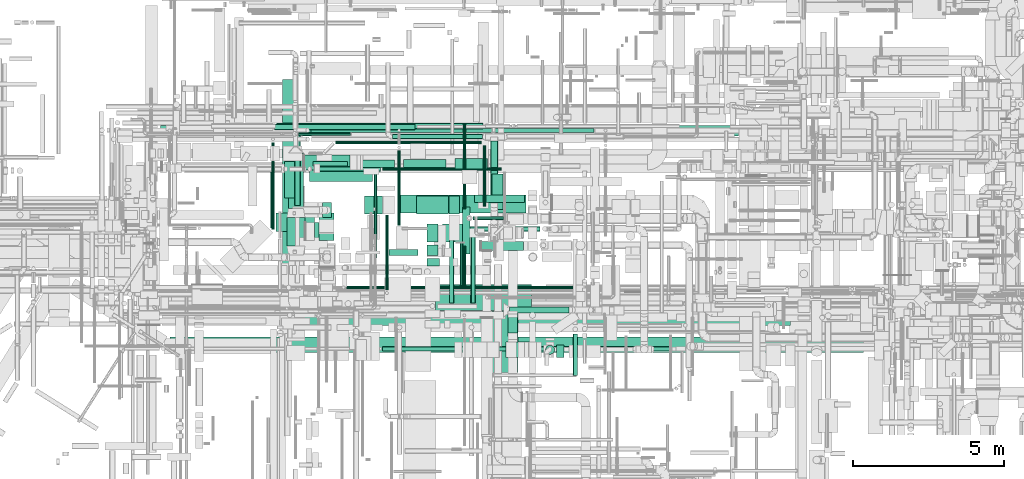
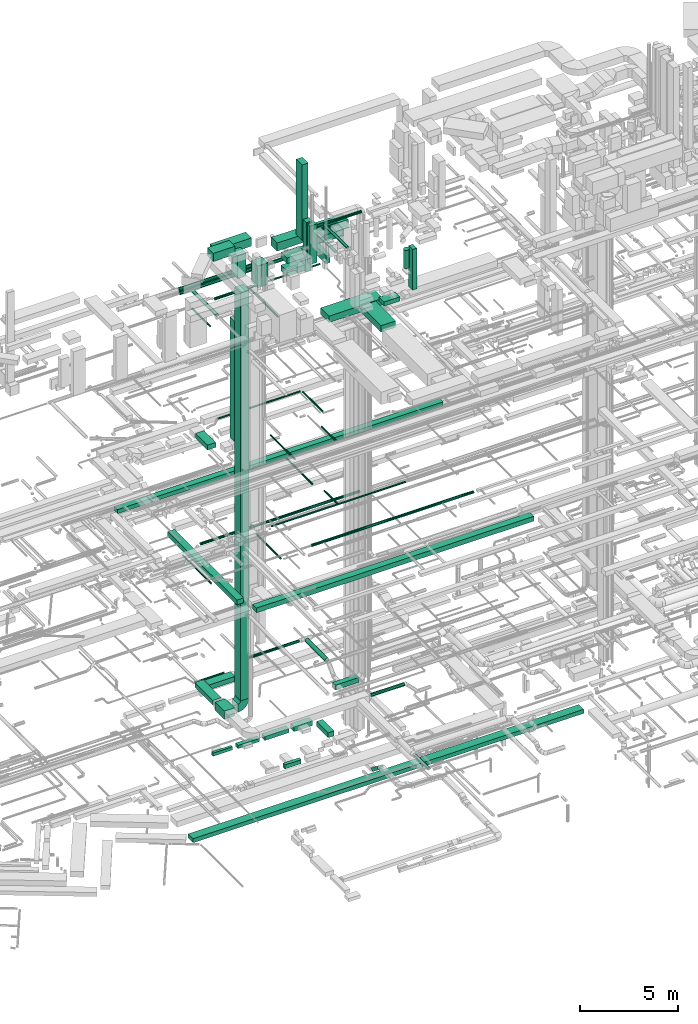
# One storey, part 32 of 337: 64 flow segments, 1 flow fitting.
"""IFC2X3 building model written with IfcOpenShell, lengths in millimetres."""

import ifcopenshell
import ifcopenshell.guid

model = None  # the IFC model being written
_history = None  # IfcOwnerHistory: only IFC2X3 demands one
_inside = {}  # id of a spatial element -> (the spatial element, [elements in it])
_under = {}  # id of a project, library or spatial element -> (it, [spatial elements below it])
_declared = {}  # id of a project -> (the project, [libraries it declares])
_typed = {}  # id of a type object -> (the type object, [elements of that type])
_made_of = {}  # id of a material, layer set ... -> (it, [elements and type objects made of it])


def new_model(schema):
    """Start an empty IFC model of exactly this schema.

    Asked for "IFC4X3", IfcOpenShell would pick the latest addendum, in which some entities
    have other attributes; the version numbers below select the first issue.
    IFC2X3 requires an IfcOwnerHistory on every rooted entity: one is made here for all.
    """
    global model, _history
    if schema == "IFC4X3":
        model = ifcopenshell.file(schema_version=(4, 3, 0, 0))
    else:
        model = ifcopenshell.file(schema=schema)
    _inside.clear()
    _under.clear()
    _declared.clear()
    _typed.clear()
    _made_of.clear()
    _history = None
    if model.schema == "IFC2X3":
        org = make("IfcOrganization", Name="unknown")
        user = make(
            "IfcPersonAndOrganization",
            ThePerson=make("IfcPerson", FamilyName="unknown"),
            TheOrganization=org,
        )
        app = make(
            "IfcApplication",
            ApplicationDeveloper=org,
            Version="unknown",
            ApplicationFullName="unknown",
            ApplicationIdentifier="unknown",
        )
        _history = make(
            "IfcOwnerHistory",
            OwningUser=user,
            OwningApplication=app,
            ChangeAction="ADDED",
            CreationDate=0,
        )
    return model


def make(cls, **values):
    """One entity of the class cls with the attributes given. An attribute that is None is left unset."""
    return model.create_entity(
        cls, **{name: value for name, value in values.items() if value is not None}
    )


def entity(cls, *values):
    """Any entity or typed value of the class cls, its attributes in the order of the schema. None: left unset."""
    e = model.create_entity(cls)
    for i, value in enumerate(values):
        if value is not None:
            e[i] = value
    return e


def rooted(cls, **values):
    """An entity with a GlobalId (a new one), such as an element, a storey or a relation."""
    return make(cls, GlobalId=ifcopenshell.guid.new(), OwnerHistory=_history, **values)


def si_unit(unit_type, name, prefix=None):
    """IfcSIUnit, for example si_unit("LENGTHUNIT", "METRE", prefix="MILLI")."""
    return make("IfcSIUnit", UnitType=unit_type, Prefix=prefix, Name=name)


def converted_unit(unit_type, name, factor, base, dimensions=None, offset=None):
    """IfcConversionBasedUnit, such as the inch: factor (a typed value) times the base unit."""
    return make(
        "IfcConversionBasedUnit"
        if offset is None
        else "IfcConversionBasedUnitWithOffset",
        ConversionOffset=offset,
        Dimensions=None
        if dimensions is None
        else entity("IfcDimensionalExponents", *dimensions),
        UnitType=unit_type,
        Name=name,
        ConversionFactor=make(
            "IfcMeasureWithUnit", ValueComponent=factor, UnitComponent=base
        ),
    )


def derived_unit(unit_type, elements):
    """IfcDerivedUnit: a product of units, each with its exponent."""
    return make(
        "IfcDerivedUnit",
        Elements=[
            make("IfcDerivedUnitElement", Unit=unit, Exponent=power)
            for unit, power in elements
        ],
        UnitType=unit_type,
    )


def assignment(units):
    """IfcUnitAssignment: the units of a project."""
    return None if units is None else make("IfcUnitAssignment", Units=units)


def point(xyz):
    """IfcCartesianPoint."""
    return None if xyz is None else make("IfcCartesianPoint", Coordinates=xyz)


def direction(xyz):
    """IfcDirection."""
    return None if xyz is None else make("IfcDirection", DirectionRatios=xyz)


def frame(location, z_axis=None, x_axis=None):
    """IfcAxis2Placement3D, a coordinate frame: its origin and axes. An axis left out is left unset."""
    return make(
        "IfcAxis2Placement3D",
        Location=point(location),
        Axis=direction(z_axis),
        RefDirection=direction(x_axis),
    )


def frame_2d(location, x_axis=None):
    """IfcAxis2Placement2D, a coordinate frame in the plane: its origin and x axis."""
    return make(
        "IfcAxis2Placement2D", Location=point(location), RefDirection=direction(x_axis)
    )


def origin():
    """The frame at (0, 0, 0) with its axes left unset."""
    return frame((0.0, 0.0, 0.0))


def origin_2d_with_axis():
    """The frame at (0, 0) in the plane with the x axis (1, 0) written out."""
    return frame_2d((0.0, 0.0), x_axis=(1.0, 0.0))


def place(relative_to, where):
    """IfcLocalPlacement: puts the frame where relative to a parent placement (None: the world)."""
    return make(
        "IfcLocalPlacement", PlacementRelTo=relative_to, RelativePlacement=where
    )


def context(
    kind, dimensions, precision=None, world=None, true_north=None, identifier=None
):
    """IfcGeometricRepresentationContext, for example the 3D "Model" context."""
    return make(
        "IfcGeometricRepresentationContext",
        ContextIdentifier=identifier,
        ContextType=kind,
        CoordinateSpaceDimension=dimensions,
        Precision=precision,
        WorldCoordinateSystem=world,
        TrueNorth=true_north,
    )


def subcontext(parent, identifier, kind, view, scale=None):
    """IfcGeometricRepresentationSubContext, for example "Body" below "Model"."""
    return make(
        "IfcGeometricRepresentationSubContext",
        ContextIdentifier=identifier,
        ContextType=kind,
        ParentContext=parent,
        TargetScale=scale,
        TargetView=view,
    )


def project(units=None, contexts=None):
    """IfcProject with its units and contexts."""
    return rooted(
        "IfcProject",
        Name="project",
        RepresentationContexts=contexts,
        UnitsInContext=assignment(units),
    )


def spatial(cls, under=None, at=None, **own):
    """A site, building, storey or space (cls), placed at a placement, below another one or the project."""
    s = rooted(cls, ObjectPlacement=at, **own)
    if under is not None:
        _under.setdefault(under.id(), (under, []))[1].append(s)
    return s


def polyline(points):
    """IfcPolyline through the points."""
    return make("IfcPolyline", Points=[point(p) for p in points])


def circle_curve(where, radius):
    """IfcCircle in the frame where."""
    return make("IfcCircle", Position=where, Radius=radius)


def parameter(value):
    """IfcParameterValue: where a trimmed curve begins or ends, as a parameter of its basis curve."""
    return model.create_entity("IfcParameterValue", value)


def trimmed(basis, trim1, trim2, sense, master):
    """IfcTrimmedCurve: the piece of a basis curve between two trims."""
    return make(
        "IfcTrimmedCurve",
        BasisCurve=basis,
        Trim1=trim1,
        Trim2=trim2,
        SenseAgreement=sense,
        MasterRepresentation=master,
    )


def segment(curve, same_sense, transition):
    """IfcCompositeCurveSegment."""
    return make(
        "IfcCompositeCurveSegment",
        Transition=transition,
        SameSense=same_sense,
        ParentCurve=curve,
    )


def composite_curve(segments, self_intersect=None):
    """IfcCompositeCurve: segments joined end to end."""
    return make("IfcCompositeCurve", Segments=segments, SelfIntersect=self_intersect)


def profile(cls, at=None, kind="AREA", **sizes):
    """A parametric profile (cls). Its sizes go by their IFC names, for example OverallWidth=200.0."""
    return make(cls, ProfileType=kind, Position=at, **sizes)


def rectangle(**sizes):
    """IfcRectangleProfileDef."""
    return profile("IfcRectangleProfileDef", **sizes)


def circle(**sizes):
    """IfcCircleProfileDef."""
    return profile("IfcCircleProfileDef", **sizes)


def outline(outer, holes=None, kind="AREA"):
    """IfcArbitraryClosedProfileDef: a profile drawn as a closed curve; with holes, ...WithVoids."""
    if holes is None:
        return make("IfcArbitraryClosedProfileDef", ProfileType=kind, OuterCurve=outer)
    return make(
        "IfcArbitraryProfileDefWithVoids",
        ProfileType=kind,
        OuterCurve=outer,
        InnerCurves=holes,
    )


def extrude(swept, where, along, depth):
    """IfcExtrudedAreaSolid: the profile swept, set in the frame where, extruded along a direction by depth."""
    return make(
        "IfcExtrudedAreaSolid",
        SweptArea=swept,
        Position=where,
        ExtrudedDirection=direction(along),
        Depth=depth,
    )


def shape(context_of_items, identifier, shape_type, items):
    """IfcShapeRepresentation: the items that make up one representation, for example the "Body"."""
    return make(
        "IfcShapeRepresentation",
        ContextOfItems=context_of_items,
        RepresentationIdentifier=identifier,
        RepresentationType=shape_type,
        Items=items,
    )


def source(mapping_origin, context_of_items, identifier, shape_type, items):
    """IfcRepresentationMap: a shape defined once, which mapped items show again and again."""
    return make(
        "IfcRepresentationMap",
        MappingOrigin=mapping_origin,
        MappedRepresentation=shape(context_of_items, identifier, shape_type, items),
    )


def transform(
    local_origin,
    x_axis=None,
    y_axis=None,
    z_axis=None,
    scale=None,
    scale2=None,
    scale3=None,
    uniform=True,
):
    """IfcCartesianTransformationOperator3D, or its non-uniform kind. x_axis, y_axis, z_axis: its Axis1, 2, 3."""
    if uniform:
        return make(
            "IfcCartesianTransformationOperator3D",
            Axis1=direction(x_axis),
            Axis2=direction(y_axis),
            LocalOrigin=point(local_origin),
            Scale=scale,
            Axis3=direction(z_axis),
        )
    return make(
        "IfcCartesianTransformationOperator3DnonUniform",
        Axis1=direction(x_axis),
        Axis2=direction(y_axis),
        LocalOrigin=point(local_origin),
        Scale=scale,
        Axis3=direction(z_axis),
        Scale2=scale2,
        Scale3=scale3,
    )


def mapped(mapping_source, mapping_target):
    """IfcMappedItem: shows the shape of a source again, moved by a transform."""
    return make(
        "IfcMappedItem", MappingSource=mapping_source, MappingTarget=mapping_target
    )


def material(Name=None, Category=None):
    """IfcMaterial."""
    return make("IfcMaterial", Name=Name, Category=Category)


def made_of(thing, what):
    """Note that an element or type object is made of a material, layer set ...; save() writes the relation."""
    if what is not None:
        _made_of.setdefault(what.id(), (what, []))[1].append(thing)
    return thing


def type_object(cls, material=None, **own):
    """A type object (cls), such as IfcWallType, which elements share."""
    return made_of(rooted(cls, **own), material)


def type_shapes(of_type, sources):
    """Give a type object the sources (RepresentationMaps) that its elements show as mapped items."""
    of_type.RepresentationMaps = sources


def element(
    cls,
    number,
    at=None,
    inside=None,
    cuts=None,
    type_object=None,
    material=None,
    context=None,
    identifier="Body",
    shape_type=None,
    held_by="IfcProductDefinitionShape",
    body=None,
    shapes=None,
    **own,
):
    """One element of the class cls, such as IfcWall. Its Tag is "e" and its number.

    at: its placement. inside: the storey or other place that contains it. cuts: it is an
    opening in that element (IfcRelVoidsElement). A single representation is given by context,
    identifier, shape_type and body (its items); several are given by shapes. held_by: the class
    of the entity that holds the representations. save() writes the other relations.
    """
    e = rooted(cls, Tag="e%d" % number, ObjectPlacement=at, **own)
    if body is not None:
        shapes = [shape(context, identifier, shape_type, body)]
    if shapes is not None:
        e.Representation = make(held_by, Representations=shapes)
    if inside is not None:
        _inside.setdefault(inside.id(), (inside, []))[1].append(e)
    if cuts is not None:
        rooted(
            "IfcRelVoidsElement", RelatingBuildingElement=cuts, RelatedOpeningElement=e
        )
    if type_object is not None:
        _typed.setdefault(type_object.id(), (type_object, []))[1].append(e)
    return made_of(e, material)


def aggregate(whole, parts):
    """IfcRelAggregates: a whole, such as a stair, and the parts it consists of."""
    return rooted("IfcRelAggregates", RelatingObject=whole, RelatedObjects=parts)


def save(model, path):
    """Write the relations noted so far, then the file.

    IfcRelAggregates (storeys below a building ...), IfcRelContainedInSpatialStructure (elements
    in a storey), IfcRelDefinesByType, IfcRelAssociatesMaterial and IfcRelDeclares: one each for
    every whole, place, type object, material and project.
    """
    for whole, parts in _under.values():
        aggregate(whole, parts)
    for where, things in _inside.values():
        rooted(
            "IfcRelContainedInSpatialStructure",
            RelatedElements=things,
            RelatingStructure=where,
        )
    for kind, things in _typed.values():
        rooted("IfcRelDefinesByType", RelatedObjects=things, RelatingType=kind)
    for what, things in _made_of.values():
        rooted("IfcRelAssociatesMaterial", RelatedObjects=things, RelatingMaterial=what)
    for by, libraries in _declared.values():
        rooted("IfcRelDeclares", RelatingContext=by, RelatedDefinitions=libraries)
    model.write(path)


model = new_model("IFC2X3")

# Units and contexts
model_context = context("Model", 3, precision=0.01, world=origin(), true_north=direction((6.12303176911189e-17, 1.0)))
body_context = subcontext(model_context, "Body", "Model", "MODEL_VIEW")
ifc_project = project(units=[si_unit("LENGTHUNIT", "METRE", prefix="MILLI"), si_unit("AREAUNIT", "SQUARE_METRE"), si_unit("VOLUMEUNIT", "CUBIC_METRE"), converted_unit("PLANEANGLEUNIT", "DEGREE", entity("IfcRatioMeasure", 0.0174532925199433), si_unit("PLANEANGLEUNIT", "RADIAN"), dimensions=[0, 0, 0, 0, 0, 0, 0]), si_unit("MASSUNIT", "GRAM", prefix="KILO"), derived_unit("MASSDENSITYUNIT", [(si_unit("MASSUNIT", "GRAM", prefix="KILO"), 1), (si_unit("LENGTHUNIT", "METRE"), -3)]), derived_unit("MOMENTOFINERTIAUNIT", [(si_unit("LENGTHUNIT", "METRE"), 4)]), si_unit("TIMEUNIT", "SECOND"), si_unit("FREQUENCYUNIT", "HERTZ"), si_unit("THERMODYNAMICTEMPERATUREUNIT", "DEGREE_CELSIUS"), derived_unit("THERMALTRANSMITTANCEUNIT", [(si_unit("MASSUNIT", "GRAM", prefix="KILO"), 1), (si_unit("THERMODYNAMICTEMPERATUREUNIT", "KELVIN"), -1), (si_unit("TIMEUNIT", "SECOND"), -3)]), derived_unit("VOLUMETRICFLOWRATEUNIT", [(si_unit("LENGTHUNIT", "METRE"), 3), (si_unit("TIMEUNIT", "SECOND"), -1)]), derived_unit("MASSFLOWRATEUNIT", [(si_unit("MASSUNIT", "GRAM", prefix="KILO"), 1), (si_unit("TIMEUNIT", "SECOND"), -1)]), derived_unit("ROTATIONALFREQUENCYUNIT", [(si_unit("TIMEUNIT", "SECOND"), -1)]), si_unit("ELECTRICCURRENTUNIT", "AMPERE"), si_unit("ELECTRICVOLTAGEUNIT", "VOLT"), si_unit("POWERUNIT", "WATT"), si_unit("FORCEUNIT", "NEWTON", prefix="KILO"), si_unit("ILLUMINANCEUNIT", "LUX"), si_unit("LUMINOUSFLUXUNIT", "LUMEN"), si_unit("LUMINOUSINTENSITYUNIT", "CANDELA"), derived_unit("USERDEFINED", [(si_unit("MASSUNIT", "GRAM", prefix="KILO"), -1), (si_unit("LENGTHUNIT", "METRE"), -2), (si_unit("TIMEUNIT", "SECOND"), 3), (si_unit("LUMINOUSFLUXUNIT", "LUMEN"), 1)]), derived_unit("LINEARVELOCITYUNIT", [(si_unit("LENGTHUNIT", "METRE"), 1), (si_unit("TIMEUNIT", "SECOND"), -1)]), si_unit("PRESSUREUNIT", "PASCAL"), derived_unit("USERDEFINED", [(si_unit("LENGTHUNIT", "METRE"), -2), (si_unit("MASSUNIT", "GRAM", prefix="KILO"), 1), (si_unit("TIMEUNIT", "SECOND"), -2)]), derived_unit("LINEARFORCEUNIT", [(si_unit("MASSUNIT", "GRAM", prefix="KILO"), 1), (si_unit("LENGTHUNIT", "METRE"), 1), (si_unit("TIMEUNIT", "SECOND"), -2), (si_unit("LENGTHUNIT", "METRE"), -1)]), derived_unit("PLANARFORCEUNIT", [(si_unit("MASSUNIT", "GRAM", prefix="KILO"), 1), (si_unit("LENGTHUNIT", "METRE"), 1), (si_unit("TIMEUNIT", "SECOND"), -2), (si_unit("LENGTHUNIT", "METRE"), -2)])], contexts=[model_context])

# Site, building, storey
site_placement = place(None, origin())
site = spatial("IfcSite", under=ifc_project, at=site_placement, CompositionType="ELEMENT")
building_placement = place(site_placement, origin())
building = spatial("IfcBuilding", under=site, at=building_placement, CompositionType="ELEMENT")
storey_placement = place(building_placement, origin())
storey = spatial("IfcBuildingStorey", under=building, at=storey_placement, CompositionType="ELEMENT", Elevation=0.0)

# Flow segments
duct_segment_type_1 = type_object("IfcDuctSegmentType", PredefinedType="NOTDEFINED")
flow_segment_1_placement = place(storey_placement, frame((19149.36, 8099.88, -975.0)))
element("IfcFlowSegment", 1, at=flow_segment_1_placement, inside=storey, type_object=duct_segment_type_1, context=body_context, shape_type="SweptSolid", body=[
    extrude(rectangle(XDim=22913.242395076, YDim=500.0, at=origin_2d_with_axis()), frame((11456.62, 250.0, 0.0)), (0.0, 0.0, 1.0), 250.0),
])
flow_segment_2_placement = place(storey_placement, frame((26394.14, 11298.59, -875.0)))
element("IfcFlowSegment", 2, at=flow_segment_2_placement, inside=storey, type_object=duct_segment_type_1, context=body_context, shape_type="SweptSolid", body=[
    extrude(rectangle(XDim=950.326972749996, YDim=200.0, at=origin_2d_with_axis()), frame((475.16, 100.0, 0.0), z_axis=(0.0, 0.0, 1.0), x_axis=(-1.0, 0.0, 0.0)), (0.0, 0.0, 1.0), 250.0),
])
flow_segment_3_placement = place(storey_placement, frame((23391.81, 8987.88, 11250.0)))
element("IfcFlowSegment", 3, at=flow_segment_3_placement, inside=storey, type_object=duct_segment_type_1, context=body_context, shape_type="SweptSolid", body=[
    extrude(rectangle(XDim=16255.0, YDim=400.0, at=origin_2d_with_axis()), frame((8127.5, 200.0, 0.0), z_axis=(0.0, 0.0, 1.0), x_axis=(-1.0, 0.0, 0.0)), (0.0, 0.0, 1.0), 300.000000000001),
])
flow_segment_4_placement = place(storey_placement, frame((29800.78, 12814.49, -1050.0)))
element("IfcFlowSegment", 4, at=flow_segment_4_placement, inside=storey, type_object=duct_segment_type_1, context=body_context, shape_type="SweptSolid", body=[
    extrude(rectangle(XDim=1184.49316975441, YDim=349.999999999998, at=origin_2d_with_axis()), frame((175.0, 592.25, 0.0), z_axis=(0.0, 0.0, 1.0), x_axis=(0.0, 1.0, 0.0)), (0.0, 0.0, 1.0), 300.0),
])
flow_segment_5_placement = place(storey_placement, frame((28575.48, 14148.99, -1050.0)))
element("IfcFlowSegment", 5, at=flow_segment_5_placement, inside=storey, type_object=duct_segment_type_1, context=body_context, shape_type="SweptSolid", body=[
    extrude(rectangle(XDim=1075.30219325002, YDim=350.000000000001, at=origin_2d_with_axis()), frame((537.65, 175.0, 0.0), z_axis=(0.0, 0.0, 1.0), x_axis=(-1.0, 0.0, 0.0)), (0.0, 0.0, 1.0), 300.0),
])
flow_segment_6_placement = place(storey_placement, frame((26875.09, 14173.99, -1025.0)))
element("IfcFlowSegment", 6, at=flow_segment_6_placement, inside=storey, type_object=duct_segment_type_1, context=body_context, shape_type="SweptSolid", body=[
    extrude(rectangle(XDim=1400.38436964089, YDim=300.000000000001, at=origin_2d_with_axis()), frame((700.19, 150.0, 0.0), z_axis=(0.0, 0.0, 1.0), x_axis=(-1.0, 0.0, 0.0)), (0.0, 0.0, 1.0), 250.0),
])
flow_segment_7_placement = place(storey_placement, frame((25325.01, 14198.99, -1000.0)))
element("IfcFlowSegment", 7, at=flow_segment_7_placement, inside=storey, type_object=duct_segment_type_1, context=body_context, shape_type="SweptSolid", body=[
    extrude(rectangle(XDim=1250.07960710933, YDim=249.999999999999, at=origin_2d_with_axis()), frame((625.04, 125.0, 0.0), z_axis=(0.0, 0.0, 1.0), x_axis=(-1.0, 0.0, 0.0)), (0.0, 0.0, 1.0), 200.0),
])
flow_segment_8_placement = place(storey_placement, frame((23875.78, 14248.99, -1000.0)))
element("IfcFlowSegment", 8, at=flow_segment_8_placement, inside=storey, type_object=duct_segment_type_1, context=body_context, shape_type="SweptSolid", body=[
    extrude(rectangle(XDim=1149.23383000004, YDim=150.000000000001, at=origin_2d_with_axis()), frame((574.62, 75.0, 0.0), z_axis=(0.0, 0.0, 1.0), x_axis=(-1.0, 0.0, 0.0)), (0.0, 0.0, 1.0), 200.0),
])
flow_segment_9_placement = place(storey_placement, frame((22877.3, 10100.83, 11250.0)))
element("IfcFlowSegment", 9, at=flow_segment_9_placement, inside=storey, type_object=duct_segment_type_1, context=body_context, shape_type="SweptSolid", body=[
    extrude(rectangle(XDim=7019.43166134936, YDim=400.000000000001, at=origin_2d_with_axis()), frame((200.0, 3509.72, 0.0), z_axis=(0.0, 0.0, 1.0), x_axis=(6.1997015819191e-08, -1.0, 0.0)), (0.0, 0.0, 1.0), 300.000000000001),
])
flow_segment_10_placement = place(storey_placement, frame((18845.0, 15240.0, 15200.0)))
element("IfcFlowSegment", 10, at=flow_segment_10_placement, inside=storey, type_object=duct_segment_type_1, context=body_context, shape_type="SweptSolid", body=[
    extrude(rectangle(XDim=19096.9567324733, YDim=350.000000000001, at=origin_2d_with_axis()), frame((9548.48, 175.0, 0.0), z_axis=(0.0, 0.0, 1.0), x_axis=(-1.0, 0.0, 0.0)), (0.0, 0.0, 1.0), 249.999999999999),
])
flow_segment_11_placement = place(storey_placement, frame((23015.55, 11611.58, 3200.0)))
element("IfcFlowSegment", 11, at=flow_segment_11_placement, inside=storey, type_object=duct_segment_type_1, context=body_context, shape_type="SweptSolid", body=[
    extrude(rectangle(XDim=940.00000000017, YDim=600.000000000002, at=origin_2d_with_axis()), frame((300.0, 470.0, 0.0), z_axis=(0.0, 0.0, 1.0), x_axis=(0.0, 1.0, 0.0)), (0.0, 0.0, 1.0), 500.0),
])
flow_segment_12_placement = place(storey_placement, frame((24079.3, 11796.01, 3849.96)))
element("IfcFlowSegment", 12, at=flow_segment_12_placement, inside=storey, type_object=duct_segment_type_1, context=body_context, shape_type="SweptSolid", body=[
    extrude(rectangle(XDim=599.999999999999, YDim=499.999999999999, at=frame_2d((0.0, 0.0), x_axis=(0.0, 1.0))), frame((250.0, 300.0, 0.04), z_axis=(0.0, 0.000140975720145072, 0.999999990062923), x_axis=(1.0, 0.0, 0.0)), (0.0, 0.0, 1.0), 25304.5541232927),
])
flow_segment_13_placement = place(storey_placement, frame((23065.55, 12851.58, 3300.0)))
element("IfcFlowSegment", 13, at=flow_segment_13_placement, inside=storey, type_object=duct_segment_type_1, context=body_context, shape_type="SweptSolid", body=[
    extrude(rectangle(XDim=1835.0, YDim=499.999999999999, at=origin_2d_with_axis()), frame((250.0, 917.5, 0.0), z_axis=(0.0, 0.0, 1.0), x_axis=(0.0, 1.0, 0.0)), (0.0, 0.0, 1.0), 300.0),
])
flow_segment_14_placement = place(storey_placement, frame((23585.55, 14126.58, 3300.0)))
element("IfcFlowSegment", 14, at=flow_segment_14_placement, inside=storey, type_object=duct_segment_type_1, context=body_context, shape_type="SweptSolid", body=[
    extrude(rectangle(XDim=1522.54344823757, YDim=500.000000000001, at=origin_2d_with_axis()), frame((761.27, 250.0, 0.0)), (0.0, 0.0, 1.0), 300.0),
])
flow_segment_15_placement = place(storey_placement, frame((29438.1, 11464.96, 2850.0)))
element("IfcFlowSegment", 15, at=flow_segment_15_placement, inside=storey, type_object=duct_segment_type_1, context=body_context, shape_type="SweptSolid", body=[
    extrude(rectangle(XDim=1401.97831714448, YDim=299.999999999999, at=origin_2d_with_axis()), frame((700.99, 150.0, 0.0), z_axis=(0.0, 0.0, 1.0), x_axis=(-1.0, 0.0, 0.0)), (0.0, 0.0, 1.0), 300.0),
])
flow_segment_16_placement = place(storey_placement, frame((22936.61, 13197.9, 18950.0)))
element("IfcFlowSegment", 16, at=flow_segment_16_placement, inside=storey, type_object=duct_segment_type_1, context=body_context, shape_type="SweptSolid", body=[
    extrude(rectangle(XDim=1205.00000000001, YDim=499.999999999999, at=origin_2d_with_axis()), frame((250.0, 602.5, 0.0), z_axis=(0.0, 0.0, 1.0), x_axis=(0.0, 1.0, 0.0)), (0.0, 0.0, 1.0), 300.000000000001),
])
flow_segment_17_placement = place(storey_placement, frame((24189.11, 12547.9, 19400.0)))
element("IfcFlowSegment", 17, at=flow_segment_17_placement, inside=storey, type_object=duct_segment_type_1, context=body_context, shape_type="SweptSolid", body=[
    extrude(rectangle(XDim=300.000000000001, YDim=500.000000000001, at=origin_2d_with_axis()), frame((150.0, 250.0, 0.0), z_axis=(0.0, 0.0, 1.0), x_axis=(-1.0, 0.0, 0.0)), (0.0, 0.0, 1.0), 7469.99999999999),
])
flow_segment_18_placement = place(storey_placement, frame((27930.62, 9489.97, 27350.0)))
element("IfcFlowSegment", 18, at=flow_segment_18_placement, inside=storey, type_object=duct_segment_type_1, context=body_context, shape_type="SweptSolid", body=[
    extrude(rectangle(XDim=3164.67871385249, YDim=850.000000000001, at=origin_2d_with_axis()), frame((1582.34, 425.0, 0.0), z_axis=(0.0, 0.0, 1.0), x_axis=(-1.0, 0.0, 0.0)), (0.0, 0.0, 1.0), 399.999999999996),
])
flow_segment_19_placement = place(storey_placement, frame((29799.65, 7432.81, 27350.0)))
element("IfcFlowSegment", 19, at=flow_segment_19_placement, inside=storey, type_object=duct_segment_type_1, context=body_context, shape_type="SweptSolid", body=[
    extrude(rectangle(XDim=2037.15580735656, YDim=850.000000000002, at=origin_2d_with_axis()), frame((425.0, 1018.58, 0.0), z_axis=(0.0, 0.0, 1.0), x_axis=(0.0, -1.0, 0.0)), (0.0, 0.0, 1.0), 400.000000000004),
])
flow_segment_20_placement = place(storey_placement, frame((25575.03, 12664.59, 28400.0)))
element("IfcFlowSegment", 20, at=flow_segment_20_placement, inside=storey, type_object=duct_segment_type_1, context=body_context, shape_type="SweptSolid", body=[
    extrude(rectangle(XDim=600.000000000002, YDim=600.0, at=origin_2d_with_axis()), frame((300.0, 300.0, 0.0), z_axis=(0.0, 0.0, 1.0), x_axis=(-1.0, 0.0, 0.0)), (0.0, 0.0, 1.0), 1350.0),
])
flow_segment_21_placement = place(storey_placement, frame((27301.6, 12664.59, 29300.0)))
element("IfcFlowSegment", 21, at=flow_segment_21_placement, inside=storey, type_object=duct_segment_type_1, context=body_context, shape_type="SweptSolid", body=[
    extrude(rectangle(XDim=1048.43711948751, YDim=600.0, at=origin_2d_with_axis()), frame((524.22, 300.0, 0.0)), (0.0, 0.0, 1.0), 349.999999999998),
])
flow_segment_22_placement = place(storey_placement, frame((27298.3, 12664.59, 28500.0)))
element("IfcFlowSegment", 22, at=flow_segment_22_placement, inside=storey, type_object=duct_segment_type_1, context=body_context, shape_type="SweptSolid", body=[
    extrude(rectangle(XDim=1051.73353470929, YDim=600.0, at=origin_2d_with_axis()), frame((525.87, 300.0, 0.0)), (0.0, 0.0, 1.0), 349.999999999998),
])
flow_segment_23_placement = place(storey_placement, frame((30327.78, 8616.87, -1175.64)))
element("IfcFlowSegment", 23, at=flow_segment_23_placement, inside=storey, type_object=duct_segment_type_1, context=body_context, shape_type="SweptSolid", body=[
    extrude(rectangle(XDim=200.0, YDim=801.272857087262, at=frame_2d((0.0, 0.0), x_axis=(0.0, 1.0))), frame((0.0, 377.15, 325.64), z_axis=(1.0, 0.0, 0.0), x_axis=(0.0, 0.787556565584183, -0.616242367908314)), (0.0, 0.0, 1.0), 300.000000000001),
])
duct_segment_type_2 = type_object("IfcDuctSegmentType", PredefinedType="NOTDEFINED")
flow_segment_24_placement = place(storey_placement, frame((32462.52, 7329.52, -681.6)))
element("IfcFlowSegment", 24, at=flow_segment_24_placement, inside=storey, type_object=duct_segment_type_2, context=body_context, shape_type="SweptSolid", body=[
    extrude(circle(Radius=80.0, at=origin_2d_with_axis()), frame((81.6, 0.0, 81.6), z_axis=(0.0, 1.0, 0.0), x_axis=(-1.0, 0.0, 0.0)), (0.0, 0.0, 1.0), 1372.40228000001),
])
flow_segment_25_placement = place(storey_placement, frame((23818.33, 15353.25, 11388.4)))
element("IfcFlowSegment", 25, at=flow_segment_25_placement, inside=storey, type_object=duct_segment_type_2, context=body_context, shape_type="SweptSolid", body=[
    extrude(circle(Radius=80.0, at=origin_2d_with_axis()), frame((0.0, 81.6, 81.6), z_axis=(1.0, 0.0, 0.0), x_axis=(0.0, 1.0, 0.0)), (0.0, 0.0, 1.0), 9336.55999999999),
])
flow_segment_26_placement = place(storey_placement, frame((22506.56, 12149.88, 11398.4)))
element("IfcFlowSegment", 26, at=flow_segment_26_placement, inside=storey, type_object=duct_segment_type_2, context=body_context, shape_type="SweptSolid", body=[
    extrude(circle(Radius=50.0, at=origin_2d_with_axis()), frame((51.6, 0.0, 51.6), z_axis=(0.0, 1.0, 0.0), x_axis=(-1.0, 0.0, 0.0)), (0.0, 0.0, 1.0), 2888.40509514351),
])
flow_segment_27_placement = place(storey_placement, frame((23396.12, 15264.53, 3048.4)))
element("IfcFlowSegment", 27, at=flow_segment_27_placement, inside=storey, type_object=duct_segment_type_2, context=body_context, shape_type="SweptSolid", body=[
    extrude(circle(Radius=50.0, at=origin_2d_with_axis()), frame((0.0, 51.6, 51.6), z_axis=(1.0, 0.0, 0.0), x_axis=(0.0, -1.0, 0.0)), (0.0, 0.0, 1.0), 1728.57864376271),
])
flow_segment_28_placement = place(storey_placement, frame((30375.55, 9397.48, 3298.4)))
element("IfcFlowSegment", 28, at=flow_segment_28_placement, inside=storey, type_object=duct_segment_type_2, context=body_context, shape_type="SweptSolid", body=[
    extrude(circle(Radius=100.0, at=origin_2d_with_axis()), frame((0.0, 101.6, 101.6), z_axis=(1.0, 0.0, 0.0), x_axis=(0.0, -1.0, 0.0)), (0.0, 0.0, 1.0), 1957.1572875254),
])
flow_segment_29_placement = place(storey_placement, frame((26513.13, 15143.34, 3518.4)))
element("IfcFlowSegment", 29, at=flow_segment_29_placement, inside=storey, type_object=duct_segment_type_2, context=body_context, shape_type="SweptSolid", body=[
    extrude(circle(Radius=80.0, at=origin_2d_with_axis()), frame((0.0, 81.6, 81.6), z_axis=(1.0, 0.0, 0.0), x_axis=(0.0, 1.0, 0.0)), (0.0, 0.0, 1.0), 2968.12500000001),
])
flow_segment_30_placement = place(storey_placement, frame((26674.61, 12288.29, 11398.4)))
element("IfcFlowSegment", 30, at=flow_segment_30_placement, inside=storey, type_object=duct_segment_type_2, context=body_context, shape_type="SweptSolid", body=[
    extrude(circle(Radius=50.0, at=origin_2d_with_axis()), frame((51.6, 0.0, 51.6), z_axis=(0.0, 1.0, 0.0), x_axis=(1.0, 0.0, 0.0)), (0.0, 0.0, 1.0), 2482.55942831076),
])
flow_segment_31_placement = place(storey_placement, frame((28838.44, 12834.31, 14923.4)))
element("IfcFlowSegment", 31, at=flow_segment_31_placement, inside=storey, type_object=duct_segment_type_2, context=body_context, shape_type="SweptSolid", body=[
    extrude(circle(Radius=50.0, at=origin_2d_with_axis()), frame((51.6, 0.0, 51.6), z_axis=(0.0, 1.0, 0.0), x_axis=(-1.0, 0.0, 0.0)), (0.0, 0.0, 1.0), 2845.68569269867),
])
flow_segment_32_placement = place(storey_placement, frame((29487.89, 12912.9, 19148.91)))
element("IfcFlowSegment", 32, at=flow_segment_32_placement, inside=storey, type_object=duct_segment_type_2, context=body_context, shape_type="SweptSolid", body=[
    extrude(circle(Radius=50.0, at=origin_2d_with_axis()), frame((51.6, 0.0, 51.6), z_axis=(0.0, 1.0, 0.0), x_axis=(-1.0, 0.0, 0.0)), (0.0, 0.0, 1.0), 2019.99999999998),
])
flow_segment_33_placement = place(storey_placement, frame((24628.94, 14981.3, 19148.91)))
element("IfcFlowSegment", 33, at=flow_segment_33_placement, inside=storey, type_object=duct_segment_type_2, context=body_context, shape_type="SweptSolid", body=[
    extrude(circle(Radius=50.0, at=origin_2d_with_axis()), frame((0.0, 51.6, 51.6), z_axis=(1.0, 0.0, 0.0), x_axis=(0.0, 1.0, 0.0)), (0.0, 0.0, 1.0), 4810.54090623425),
])
flow_segment_34_placement = place(storey_placement, frame((26267.94, 10157.12, 18988.4)))
element("IfcFlowSegment", 34, at=flow_segment_34_placement, inside=storey, type_object=duct_segment_type_2, context=body_context, shape_type="SweptSolid", body=[
    extrude(circle(Radius=50.0, at=origin_2d_with_axis()), frame((51.6, 0.0, 51.6), z_axis=(0.0, 1.0, 0.0), x_axis=(1.0, 0.0, 0.0)), (0.0, 0.0, 1.0), 2480.00000000003),
])
flow_segment_35_placement = place(storey_placement, frame((28737.65, 10307.4, 19198.4)))
element("IfcFlowSegment", 35, at=flow_segment_35_placement, inside=storey, type_object=duct_segment_type_2, context=body_context, shape_type="SweptSolid", body=[
    extrude(circle(Radius=50.0, at=origin_2d_with_axis()), frame((51.6, 0.0, 51.6), z_axis=(0.0, 1.0, 0.0), x_axis=(1.0, 0.0, 0.0)), (0.0, 0.0, 1.0), 1423.3498418298),
])
flow_segment_36_placement = place(storey_placement, frame((26170.56, 8138.04, 14843.4)))
element("IfcFlowSegment", 36, at=flow_segment_36_placement, inside=storey, type_object=duct_segment_type_2, context=body_context, shape_type="SweptSolid", body=[
    extrude(circle(Radius=80.0, at=origin_2d_with_axis()), frame((0.0, 81.6, 81.6), z_axis=(1.0, 0.0, 0.0), x_axis=(0.0, 1.0, 0.0)), (0.0, 0.0, 1.0), 9500.0),
])
flow_segment_37_placement = place(storey_placement, frame((28838.44, 10316.29, 15248.4)))
element("IfcFlowSegment", 37, at=flow_segment_37_placement, inside=storey, type_object=duct_segment_type_2, context=body_context, shape_type="SweptSolid", body=[
    extrude(circle(Radius=50.0, at=origin_2d_with_axis()), frame((51.6, 0.0, 51.6), z_axis=(0.0, 1.0, 0.0), x_axis=(1.0, 0.0, 0.0)), (0.0, 0.0, 1.0), 1297.50763646129),
])
flow_segment_38_placement = place(storey_placement, frame((24984.03, 10194.7, 15248.4)))
element("IfcFlowSegment", 38, at=flow_segment_38_placement, inside=storey, type_object=duct_segment_type_2, context=body_context, shape_type="SweptSolid", body=[
    extrude(circle(Radius=50.0, at=origin_2d_with_axis()), frame((0.0, 51.6, 51.6), z_axis=(1.0, 0.0, 0.0), x_axis=(0.0, 1.0, 0.0)), (0.0, 0.0, 1.0), 7861.00000000001),
])
flow_segment_39_placement = place(storey_placement, frame((25886.0, 11209.26, 27318.4)))
element("IfcFlowSegment", 39, at=flow_segment_39_placement, inside=storey, type_object=duct_segment_type_2, context=body_context, shape_type="SweptSolid", body=[
    extrude(circle(Radius=50.0, at=origin_2d_with_axis()), frame((51.6, 0.0, 51.6), z_axis=(0.0, 1.0, 0.0), x_axis=(-1.0, 0.0, 0.0)), (0.0, 0.0, 1.0), 2848.2403330758),
])
flow_segment_40_placement = place(storey_placement, frame((22613.22, 15448.43, 27498.4)))
element("IfcFlowSegment", 40, at=flow_segment_40_placement, inside=storey, type_object=duct_segment_type_2, context=body_context, shape_type="SweptSolid", body=[
    extrude(circle(Radius=100.0, at=origin_2d_with_axis()), frame((0.0, 101.6, 101.6), z_axis=(1.0, 0.0, 0.0), x_axis=(0.0, -1.0, 0.0)), (0.0, 0.0, 1.0), 4630.0),
])
flow_segment_41_placement = place(storey_placement, frame((22478.34, 12199.26, 27318.4)))
element("IfcFlowSegment", 41, at=flow_segment_41_placement, inside=storey, type_object=duct_segment_type_2, context=body_context, shape_type="SweptSolid", body=[
    extrude(circle(Radius=50.0, at=origin_2d_with_axis()), frame((51.6, 0.0, 51.6), z_axis=(0.0, 1.0, 0.0), x_axis=(-1.0, 0.0, 0.0)), (0.0, 0.0, 1.0), 1858.24033307586),
])
flow_segment_42_placement = place(storey_placement, frame((23260.83, 12942.9, 27218.4)))
element("IfcFlowSegment", 42, at=flow_segment_42_placement, inside=storey, type_object=duct_segment_type_2, context=body_context, shape_type="SweptSolid", body=[
    extrude(circle(Radius=100.0, at=origin_2d_with_axis()), frame((101.6, 0.0, 101.6), z_axis=(0.0, 1.0, 0.0), x_axis=(-1.0, 0.0, 0.0)), (0.0, 0.0, 1.0), 2519.0899698753),
])
flow_segment_43_placement = place(storey_placement, frame((22682.42, 15480.39, 27218.4)))
element("IfcFlowSegment", 43, at=flow_segment_43_placement, inside=storey, type_object=duct_segment_type_2, context=body_context, shape_type="SweptSolid", body=[
    extrude(circle(Radius=100.0, at=origin_2d_with_axis()), frame((0.0, 101.6, 101.6), z_axis=(1.0, 0.0, 0.0), x_axis=(0.0, 1.0, 0.0)), (0.0, 0.0, 1.0), 6820.0),
])
flow_segment_44_placement = place(storey_placement, frame((31558.4, 8032.9, 30252.0)))
element("IfcFlowSegment", 44, at=flow_segment_44_placement, inside=storey, type_object=duct_segment_type_2, context=body_context, shape_type="SweptSolid", body=[
    extrude(circle(Radius=150.0, at=origin_2d_with_axis()), frame((151.6, 151.6, 0.0), z_axis=(0.0, 0.0, 1.0), x_axis=(0.0, -1.0, 0.0)), (0.0, 0.0, 1.0), 1147.99997499998),
])
flow_segment_45_placement = place(storey_placement, frame((29166.64, 12470.96, 30790.47)))
element("IfcFlowSegment", 45, at=flow_segment_45_placement, inside=storey, type_object=duct_segment_type_2, context=body_context, shape_type="SweptSolid", body=[
    extrude(circle(Radius=60.0, at=origin_2d_with_axis()), frame((0.0, 61.6, 61.6), z_axis=(1.0, 0.0, 6.1119419474623e-06), x_axis=(0.0, 1.0, 0.0)), (0.0, 0.0, 1.0), 1011.95889111105),
])
flow_segment_46_placement = place(storey_placement, frame((29085.52, 9727.84, 31323.41)))
element("IfcFlowSegment", 46, at=flow_segment_46_placement, inside=storey, type_object=duct_segment_type_2, context=body_context, shape_type="SweptSolid", body=[
    extrude(circle(Radius=80.0, at=origin_2d_with_axis()), frame((81.6, 0.0, 81.6), z_axis=(0.0, 1.0, 0.0), x_axis=(1.0, 0.0, 0.0)), (0.0, 0.0, 1.0), 2350.8115762939),
])
flow_segment_47_placement = place(storey_placement, frame((28347.12, 12097.06, 31323.47)))
element("IfcFlowSegment", 47, at=flow_segment_47_placement, inside=storey, type_object=duct_segment_type_2, context=body_context, shape_type="SweptSolid", body=[
    extrude(circle(Radius=80.0, at=origin_2d_with_axis()), frame((0.0, 81.6, 81.6), z_axis=(1.0, 0.0, 0.0), x_axis=(0.0, -1.0, 0.0)), (0.0, 0.0, 1.0), 3030.00006285468),
])
flow_segment_48_placement = place(storey_placement, frame((28381.77, 9727.84, 31323.41)))
element("IfcFlowSegment", 48, at=flow_segment_48_placement, inside=storey, type_object=duct_segment_type_2, context=body_context, shape_type="SweptSolid", body=[
    extrude(circle(Radius=80.0, at=origin_2d_with_axis()), frame((81.6, 0.0, 81.6), z_axis=(0.0, 1.0, 0.0), x_axis=(1.0, 0.0, 0.0)), (0.0, 0.0, 1.0), 2350.8115762939),
])
flow_segment_49_placement = place(storey_placement, frame((29734.66, 13030.74, 3473.4)))
element("IfcFlowSegment", 49, at=flow_segment_49_placement, inside=storey, type_object=duct_segment_type_2, context=body_context, shape_type="SweptSolid", body=[
    extrude(circle(Radius=125.0, at=origin_2d_with_axis()), frame((126.6, 0.0, 126.6), z_axis=(0.0, 1.0, 0.0), x_axis=(1.0, 0.0, 0.0)), (0.0, 0.0, 1.0), 2049.19735779041),
])
flow_segment_50_placement = place(storey_placement, frame((26173.69, 14103.37, 27348.4)))
element("IfcFlowSegment", 50, at=flow_segment_50_placement, inside=storey, type_object=duct_segment_type_2, context=body_context, shape_type="SweptSolid", body=[
    extrude(circle(Radius=50.0, at=origin_2d_with_axis()), frame((0.0, 51.6, 51.6), z_axis=(1.0, 0.0, 0.0), x_axis=(0.0, 1.0, 0.0)), (0.0, 0.0, 1.0), 3926.0),
])
flow_segment_51_placement = place(storey_placement, frame((23911.97, 14073.37, 27318.4)))
element("IfcFlowSegment", 51, at=flow_segment_51_placement, inside=storey, type_object=duct_segment_type_2, context=body_context, shape_type="SweptSolid", body=[
    extrude(circle(Radius=80.0, at=origin_2d_with_axis()), frame((0.0, 81.6, 81.6), z_axis=(1.0, 0.0, 0.0), x_axis=(0.0, 1.0, 0.0)), (0.0, 0.0, 1.0), 2201.72575114485),
])
duct_segment_type_3 = type_object("IfcDuctSegmentType", PredefinedType="NOTDEFINED")
flow_segment_52_placement = place(storey_placement, frame((28820.03, 11345.06, 29550.01)))
element("IfcFlowSegment", 52, at=flow_segment_52_placement, inside=storey, type_object=duct_segment_type_3, context=body_context, shape_type="SweptSolid", body=[
    extrude(rectangle(XDim=1559.43538529869, YDim=249.999999999999, at=origin_2d_with_axis()), frame((125.0, 779.72, 0.0), z_axis=(0.0, 0.0, 1.0), x_axis=(0.0, 1.0, 0.0)), (0.0, 0.0, 1.0), 499.999999999999),
])
flow_segment_53_placement = place(storey_placement, frame((27654.24, 10945.06, 30150.01)))
element("IfcFlowSegment", 53, at=flow_segment_53_placement, inside=storey, type_object=duct_segment_type_3, context=body_context, shape_type="SweptSolid", body=[
    extrude(rectangle(XDim=399.999999999996, YDim=249.999999999999, at=origin_2d_with_axis()), frame((200.0, 125.0, 0.0)), (0.0, 0.0, 1.0), 2389.9879117318),
])
flow_segment_54_placement = place(storey_placement, frame((23762.03, 13742.74, 30250.0)))
element("IfcFlowSegment", 54, at=flow_segment_54_placement, inside=storey, type_object=duct_segment_type_3, context=body_context, shape_type="SweptSolid", body=[
    extrude(rectangle(XDim=2079.99999999999, YDim=600.0, at=origin_2d_with_axis()), frame((1040.0, 300.0, 0.0)), (0.0, 0.0, 1.0), 499.999999999999),
])
flow_segment_55_placement = place(storey_placement, frame((26742.03, 12698.57, 30250.0)))
element("IfcFlowSegment", 55, at=flow_segment_55_placement, inside=storey, type_object=duct_segment_type_3, context=body_context, shape_type="SweptSolid", body=[
    extrude(rectangle(XDim=4172.51256418071, YDim=600.0, at=origin_2d_with_axis()), frame((2086.26, 300.0, 0.0), z_axis=(0.0, 0.0, 1.0), x_axis=(-1.0, 0.0, 0.0)), (0.0, 0.0, 1.0), 499.999999999999),
])
flow_segment_56_placement = place(storey_placement, frame((30258.85, 7934.5, 28500.0)))
element("IfcFlowSegment", 56, at=flow_segment_56_placement, inside=storey, type_object=duct_segment_type_3, context=body_context, shape_type="SweptSolid", body=[
    extrude(rectangle(XDim=938.182301178789, YDim=500.0, at=origin_2d_with_axis()), frame((469.09, 250.0, 0.0)), (0.0, 0.0, 1.0), 250.000000000004),
])
flow_segment_57_placement = place(storey_placement, frame((31929.5, 7934.51, 28900.0)))
element("IfcFlowSegment", 57, at=flow_segment_57_placement, inside=storey, type_object=duct_segment_type_3, context=body_context, shape_type="SweptSolid", body=[
    extrude(rectangle(XDim=400.0, YDim=249.999999999999, at=origin_2d_with_axis()), frame((125.0, 200.0, 0.0), z_axis=(0.0, -4.89204717268876e-09, 1.0), x_axis=(0.0, 1.0, 4.89204717268876e-09)), (0.0, 0.0, 1.0), 2525.00000627869),
])
flow_segment_58_placement = place(storey_placement, frame((27654.24, 11295.06, 30370.0)))
element("IfcFlowSegment", 58, at=flow_segment_58_placement, inside=storey, type_object=duct_segment_type_3, context=body_context, shape_type="SweptSolid", body=[
    extrude(rectangle(XDim=349.999999999998, YDim=350.000000000001, at=origin_2d_with_axis()), frame((175.0, 175.0, 0.0)), (0.0, 0.0, 1.0), 2170.00002500007),
])
flow_segment_59_placement = place(storey_placement, frame((28370.03, 12664.59, 28400.0)))
element("IfcFlowSegment", 59, at=flow_segment_59_placement, inside=storey, type_object=duct_segment_type_3, context=body_context, shape_type="SweptSolid", body=[
    extrude(rectangle(XDim=349.999999999998, YDim=600.0, at=origin_2d_with_axis()), frame((175.0, 300.0, 0.0), z_axis=(0.0, 0.0, 1.0), x_axis=(-1.0, 0.0, 0.0)), (0.0, 0.0, 1.0), 1220.00002499997),
])
flow_segment_60_placement = place(storey_placement, frame((27654.24, 11745.06, 31175.0)))
element("IfcFlowSegment", 60, at=flow_segment_60_placement, inside=storey, type_object=duct_segment_type_3, context=body_context, shape_type="SweptSolid", body=[
    extrude(rectangle(XDim=349.999999999998, YDim=600.0, at=origin_2d_with_axis()), frame((175.0, 300.0, 0.0)), (0.0, 0.0, 1.0), 4675.00000000002),
])
flow_segment_61_placement = place(storey_placement, frame((29220.03, 13054.49, 29550.01)))
element("IfcFlowSegment", 61, at=flow_segment_61_placement, inside=storey, type_object=duct_segment_type_3, context=body_context, shape_type="SweptSolid", body=[
    extrude(rectangle(XDim=1645.08132958815, YDim=249.999999999999, at=origin_2d_with_axis()), frame((822.54, 125.0, 0.0)), (0.0, 0.0, 1.0), 499.999999999999),
])
flow_segment_62_placement = place(storey_placement, frame((28154.24, 11745.06, 30675.0)))
element("IfcFlowSegment", 62, at=flow_segment_62_placement, inside=storey, type_object=duct_segment_type_3, context=body_context, shape_type="SweptSolid", body=[
    extrude(rectangle(XDim=776.97329738538, YDim=600.0, at=origin_2d_with_axis()), frame((388.49, 300.0, 0.0)), (0.0, 0.0, 1.0), 349.999999999998),
])
flow_segment_63_placement = place(storey_placement, frame((22661.4, 12098.31, 31400.0)))
element("IfcFlowSegment", 63, at=flow_segment_63_placement, inside=storey, type_object=duct_segment_type_3, context=body_context, shape_type="SweptSolid", body=[
    extrude(rectangle(XDim=1267.90195093996, YDim=600.0, at=origin_2d_with_axis()), frame((633.95, 300.0, 0.0), z_axis=(0.0, 0.0, 1.0), x_axis=(-1.0, 0.0, 0.0)), (0.0, 0.0, 1.0), 499.999999999999),
])
flow_segment_64_placement = place(storey_placement, frame((24079.3, 12098.31, 29827.05)))
element("IfcFlowSegment", 64, at=flow_segment_64_placement, inside=storey, type_object=duct_segment_type_3, context=body_context, shape_type="SweptSolid", body=[
    extrude(rectangle(XDim=499.999999999999, YDim=600.0, at=origin_2d_with_axis()), frame((250.0, 300.0, 0.0), z_axis=(0.0, 0.0, 1.0), x_axis=(-1.0, 0.0, 0.0)), (0.0, 0.0, 1.0), 1422.95472144781),
])

# Flow fitting
ifc_material = material()
duct_fitting_type = type_object("IfcDuctFittingType", PredefinedType="NOTDEFINED", material=ifc_material)
shared_shape = source(origin(), body_context, "Body", "SweptSolid", [
    extrude(outline(composite_curve([segment(polyline([(-450.0, -200.0), (50.0, -200.0)]), True, "CONTINUOUS"), segment(trimmed(circle_curve(frame_2d((200.0, -200.0), x_axis=(0.0, 1.0)), 150.0), [parameter(0.0)], [parameter(90.0000000000001)], True, "PARAMETER"), False, "CONTINUOUS"), segment(polyline([(200.0, -50.0), (200.0, 450.0)]), True, "CONTINUOUS"), segment(trimmed(circle_curve(frame_2d((200.0, -200.0), x_axis=(0.0, 1.0)), 650.0), [parameter(0.0)], [parameter(90.0000000000001)], True, "PARAMETER"), True, "CONTINUOUS")], self_intersect=False)), frame((-200.0, 200.0, -300.0), z_axis=(0.0, 0.0, 1.0), x_axis=(-1.0, 0.0, 0.0)), (0.0, 0.0, 1.0), 600.0),
])
type_shapes(duct_fitting_type, [shared_shape])
flow_fitting_placement = place(storey_placement, frame((24329.3, 12095.95, 3450.0), z_axis=(0.0, -0.999999990062923, 0.000140975720145511), x_axis=(1.0, 0.0, 0.0)))
element("IfcFlowFitting", 65, at=flow_fitting_placement, inside=storey, type_object=duct_fitting_type, material=ifc_material, context=body_context, shape_type="MappedRepresentation", body=[
    mapped(shared_shape, transform((0.0, 0.0, 0.0), scale=1.0)),
])

save(model, "model.ifc")
